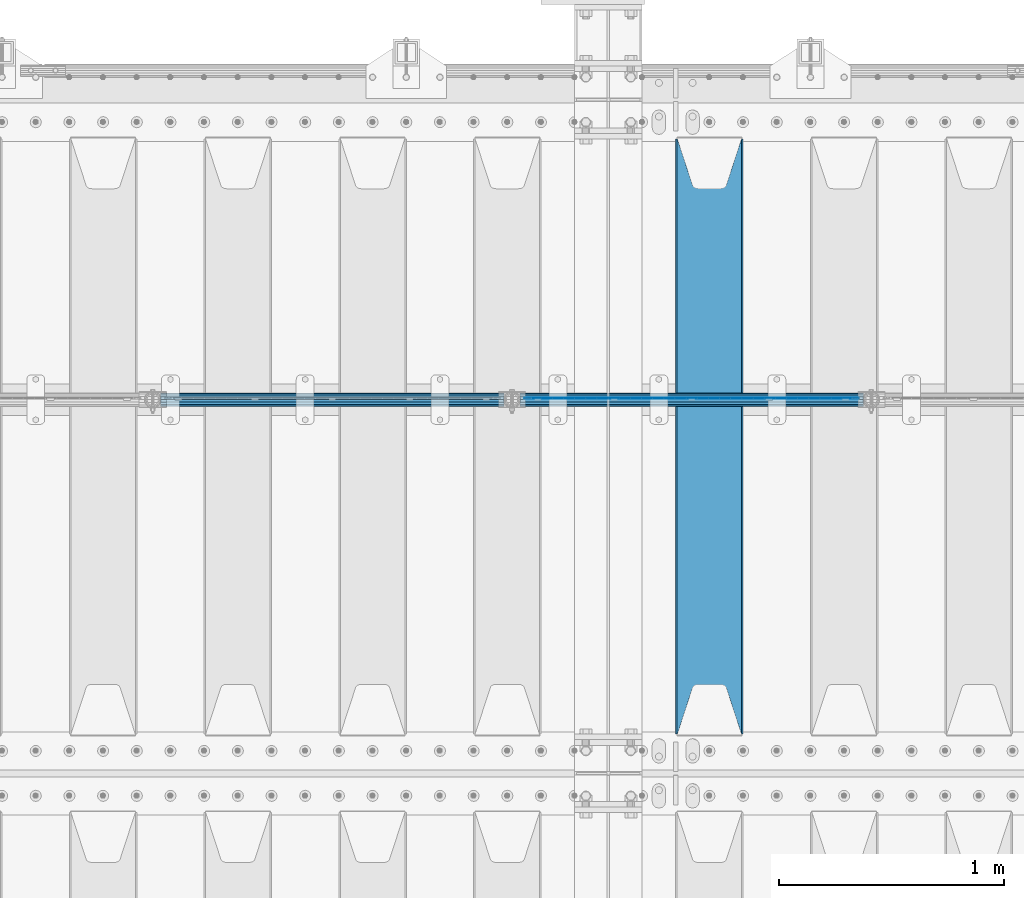
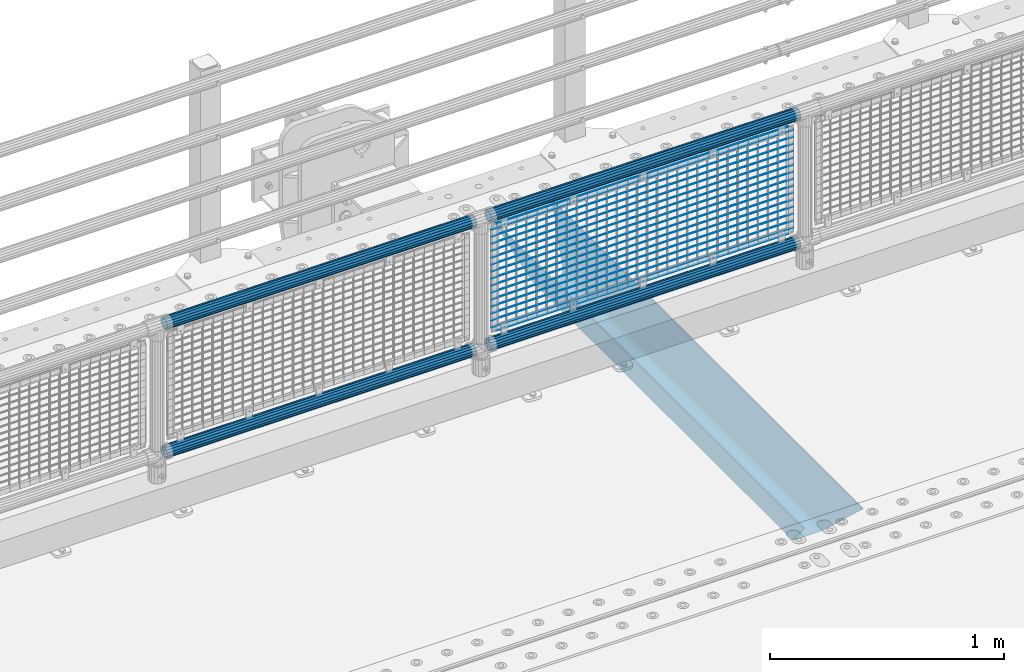
# One storey, part 126 of 257: 22 beams.
"""IFC2X3 building model written with IfcOpenShell, lengths in millimetres."""

import ifcopenshell
import ifcopenshell.guid

model = None  # the IFC model being written
_history = None  # IfcOwnerHistory: only IFC2X3 demands one
_inside = {}  # id of a spatial element -> (the spatial element, [elements in it])
_under = {}  # id of a project, library or spatial element -> (it, [spatial elements below it])
_declared = {}  # id of a project -> (the project, [libraries it declares])
_typed = {}  # id of a type object -> (the type object, [elements of that type])
_made_of = {}  # id of a material, layer set ... -> (it, [elements and type objects made of it])


def new_model(schema):
    """Start an empty IFC model of exactly this schema.

    Asked for "IFC4X3", IfcOpenShell would pick the latest addendum, in which some entities
    have other attributes; the version numbers below select the first issue.
    IFC2X3 requires an IfcOwnerHistory on every rooted entity: one is made here for all.
    """
    global model, _history
    if schema == "IFC4X3":
        model = ifcopenshell.file(schema_version=(4, 3, 0, 0))
    else:
        model = ifcopenshell.file(schema=schema)
    _inside.clear()
    _under.clear()
    _declared.clear()
    _typed.clear()
    _made_of.clear()
    _history = None
    if model.schema == "IFC2X3":
        org = make("IfcOrganization", Name="unknown")
        user = make(
            "IfcPersonAndOrganization",
            ThePerson=make("IfcPerson", FamilyName="unknown"),
            TheOrganization=org,
        )
        app = make(
            "IfcApplication",
            ApplicationDeveloper=org,
            Version="unknown",
            ApplicationFullName="unknown",
            ApplicationIdentifier="unknown",
        )
        _history = make(
            "IfcOwnerHistory",
            OwningUser=user,
            OwningApplication=app,
            ChangeAction="ADDED",
            CreationDate=0,
        )
    return model


def make(cls, **values):
    """One entity of the class cls with the attributes given. An attribute that is None is left unset."""
    return model.create_entity(
        cls, **{name: value for name, value in values.items() if value is not None}
    )


def rooted(cls, **values):
    """An entity with a GlobalId (a new one), such as an element, a storey or a relation."""
    return make(cls, GlobalId=ifcopenshell.guid.new(), OwnerHistory=_history, **values)


def si_unit(unit_type, name, prefix=None):
    """IfcSIUnit, for example si_unit("LENGTHUNIT", "METRE", prefix="MILLI")."""
    return make("IfcSIUnit", UnitType=unit_type, Prefix=prefix, Name=name)


def assignment(units):
    """IfcUnitAssignment: the units of a project."""
    return None if units is None else make("IfcUnitAssignment", Units=units)


def point(xyz):
    """IfcCartesianPoint."""
    return None if xyz is None else make("IfcCartesianPoint", Coordinates=xyz)


def direction(xyz):
    """IfcDirection."""
    return None if xyz is None else make("IfcDirection", DirectionRatios=xyz)


def frame(location, z_axis=None, x_axis=None):
    """IfcAxis2Placement3D, a coordinate frame: its origin and axes. An axis left out is left unset."""
    return make(
        "IfcAxis2Placement3D",
        Location=point(location),
        Axis=direction(z_axis),
        RefDirection=direction(x_axis),
    )


def origin_with_axes():
    """The frame at (0, 0, 0) with the z axis (0, 0, 1) and the x axis (1, 0, 0) written out."""
    return frame((0.0, 0.0, 0.0), z_axis=(0.0, 0.0, 1.0), x_axis=(1.0, 0.0, 0.0))


def place(relative_to, where):
    """IfcLocalPlacement: puts the frame where relative to a parent placement (None: the world)."""
    return make(
        "IfcLocalPlacement", PlacementRelTo=relative_to, RelativePlacement=where
    )


def context(
    kind, dimensions, precision=None, world=None, true_north=None, identifier=None
):
    """IfcGeometricRepresentationContext, for example the 3D "Model" context."""
    return make(
        "IfcGeometricRepresentationContext",
        ContextIdentifier=identifier,
        ContextType=kind,
        CoordinateSpaceDimension=dimensions,
        Precision=precision,
        WorldCoordinateSystem=world,
        TrueNorth=true_north,
    )


def subcontext(parent, identifier, kind, view, scale=None):
    """IfcGeometricRepresentationSubContext, for example "Body" below "Model"."""
    return make(
        "IfcGeometricRepresentationSubContext",
        ContextIdentifier=identifier,
        ContextType=kind,
        ParentContext=parent,
        TargetScale=scale,
        TargetView=view,
    )


def project(units=None, contexts=None):
    """IfcProject with its units and contexts."""
    return rooted(
        "IfcProject",
        Name="project",
        RepresentationContexts=contexts,
        UnitsInContext=assignment(units),
    )


def spatial(cls, under=None, at=None, **own):
    """A site, building, storey or space (cls), placed at a placement, below another one or the project."""
    s = rooted(cls, ObjectPlacement=at, **own)
    if under is not None:
        _under.setdefault(under.id(), (under, []))[1].append(s)
    return s


def faces_of(points, faces, orient=None, outer=None):
    """IfcFace entities. A face is a list of loops; a loop is a list of indices into points, from 0.

    orient and outer hold one flag for each loop. By default every Orientation is true, the
    first loop of a face is its IfcFaceOuterBound and the others are IfcFaceBound.
    """
    made = []
    for i, loops in enumerate(faces):
        bounds = []
        for j, loop in enumerate(loops):
            is_outer = j == 0 if outer is None else outer[i][j]
            bounds.append(
                make(
                    "IfcFaceOuterBound" if is_outer else "IfcFaceBound",
                    Bound=make("IfcPolyLoop", Polygon=[points[k] for k in loop]),
                    Orientation=True if orient is None else orient[i][j],
                )
            )
        made.append(make("IfcFace", Bounds=bounds))
    return made


def faceted_brep(points, faces, orient=None, outer=None, voids=None):
    """IfcFacetedBrep: a solid bounded by flat faces; with voids (closed shells), ...WithVoids."""
    shared = [point(p) for p in points]
    hull = make("IfcClosedShell", CfsFaces=faces_of(shared, faces, orient, outer))
    if voids is None:
        return make("IfcFacetedBrep", Outer=hull)
    return make(
        "IfcFacetedBrepWithVoids",
        Outer=hull,
        Voids=[
            make(cls, CfsFaces=faces_of(shared, fs, o, b)) for cls, fs, o, b in voids
        ],
    )


def shape(context_of_items, identifier, shape_type, items):
    """IfcShapeRepresentation: the items that make up one representation, for example the "Body"."""
    return make(
        "IfcShapeRepresentation",
        ContextOfItems=context_of_items,
        RepresentationIdentifier=identifier,
        RepresentationType=shape_type,
        Items=items,
    )


def material(Name=None, Category=None):
    """IfcMaterial."""
    return make("IfcMaterial", Name=Name, Category=Category)


def made_of(thing, what):
    """Note that an element or type object is made of a material, layer set ...; save() writes the relation."""
    if what is not None:
        _made_of.setdefault(what.id(), (what, []))[1].append(thing)
    return thing


def type_object(cls, material=None, **own):
    """A type object (cls), such as IfcWallType, which elements share."""
    return made_of(rooted(cls, **own), material)


def element(
    cls,
    number,
    at=None,
    inside=None,
    cuts=None,
    type_object=None,
    material=None,
    context=None,
    identifier="Body",
    shape_type=None,
    held_by="IfcProductDefinitionShape",
    body=None,
    shapes=None,
    **own,
):
    """One element of the class cls, such as IfcWall. Its Tag is "e" and its number.

    at: its placement. inside: the storey or other place that contains it. cuts: it is an
    opening in that element (IfcRelVoidsElement). A single representation is given by context,
    identifier, shape_type and body (its items); several are given by shapes. held_by: the class
    of the entity that holds the representations. save() writes the other relations.
    """
    e = rooted(cls, Tag="e%d" % number, ObjectPlacement=at, **own)
    if body is not None:
        shapes = [shape(context, identifier, shape_type, body)]
    if shapes is not None:
        e.Representation = make(held_by, Representations=shapes)
    if inside is not None:
        _inside.setdefault(inside.id(), (inside, []))[1].append(e)
    if cuts is not None:
        rooted(
            "IfcRelVoidsElement", RelatingBuildingElement=cuts, RelatedOpeningElement=e
        )
    if type_object is not None:
        _typed.setdefault(type_object.id(), (type_object, []))[1].append(e)
    return made_of(e, material)


def aggregate(whole, parts):
    """IfcRelAggregates: a whole, such as a stair, and the parts it consists of."""
    return rooted("IfcRelAggregates", RelatingObject=whole, RelatedObjects=parts)


def save(model, path):
    """Write the relations noted so far, then the file.

    IfcRelAggregates (storeys below a building ...), IfcRelContainedInSpatialStructure (elements
    in a storey), IfcRelDefinesByType, IfcRelAssociatesMaterial and IfcRelDeclares: one each for
    every whole, place, type object, material and project.
    """
    for whole, parts in _under.values():
        aggregate(whole, parts)
    for where, things in _inside.values():
        rooted(
            "IfcRelContainedInSpatialStructure",
            RelatedElements=things,
            RelatingStructure=where,
        )
    for kind, things in _typed.values():
        rooted("IfcRelDefinesByType", RelatedObjects=things, RelatingType=kind)
    for what, things in _made_of.values():
        rooted("IfcRelAssociatesMaterial", RelatedObjects=things, RelatingMaterial=what)
    for by, libraries in _declared.values():
        rooted("IfcRelDeclares", RelatingContext=by, RelatedDefinitions=libraries)
    model.write(path)


model = new_model("IFC2X3")

# Units and contexts
model_context = context("Model", 3, precision=1e-05, world=origin_with_axes())
body_context = subcontext(model_context, "Body", "Model", "MODEL_VIEW")
ifc_project = project(units=[si_unit("LENGTHUNIT", "METRE", prefix="MILLI"), si_unit("AREAUNIT", "SQUARE_METRE"), si_unit("VOLUMEUNIT", "CUBIC_METRE"), si_unit("MASSUNIT", "GRAM", prefix="KILO"), si_unit("TIMEUNIT", "SECOND"), si_unit("PLANEANGLEUNIT", "RADIAN"), si_unit("SOLIDANGLEUNIT", "STERADIAN"), si_unit("THERMODYNAMICTEMPERATUREUNIT", "DEGREE_CELSIUS"), si_unit("LUMINOUSINTENSITYUNIT", "LUMEN")], contexts=[model_context])

# Site, building, storey
site_placement = place(None, origin_with_axes())
site = spatial("IfcSite", under=ifc_project, at=site_placement, CompositionType="ELEMENT")
building_placement = place(site_placement, origin_with_axes())
building = spatial("IfcBuilding", under=site, at=building_placement, Name="Standard", CompositionType="ELEMENT")
storey_placement = place(building_placement, origin_with_axes())
storey = spatial("IfcBuildingStorey", under=building, at=storey_placement, Name="Undefined", CompositionType="ELEMENT", Elevation=0.0)

# Beams
ifc_material_1 = material(Name="STEEL/S355N")
beam_type_1 = type_object("IfcBeamType", PredefinedType="NOTDEFINED")
beam_1_placement = place(storey_placement, frame((55150.0, 9175.0, -115.0), z_axis=(0.0, 0.0, 1.0), x_axis=(0.0, 1.0, 0.0)))
element("IfcBeam", 1, at=beam_1_placement, inside=storey, type_object=beam_type_1, material=ifc_material_1, context=body_context, shape_type="Brep", body=[
    faceted_brep([(0.0, 150.0, 115.0), (0.0, 143.690000000002, 115.0), (2650.00000000297, 143.690000000002, 115.0), (2650.00000000297, 150.0, 115.0), (2650.00000000297, 142.059565218406, 110.0000000031), (2650.00000000297, 148.369565218403, 110.0000000031), (2441.90079219208, -80.1103600731149, -98.0992078077845), (2437.7588105432, -77.5672621345584, -102.241189456673), (2434.06523489746, -74.4080125315522, -105.934765102404), (2430.91086095089, -70.7102721255724, -109.089139048974), (2428.37322971128, -66.5649389910031, -111.626770288588), (2426.51472138055, -62.0739139532889, -113.485278619323), (2425.38102192091, -57.3475956567636, -114.618978078955), (2424.99999999987, -52.5021667386536, -115.0), (2424.99999999987, 52.5021667386536, -115.0), (2425.38102192091, 57.3475956567636, -114.618978078955), (2426.51472138055, 62.0739139532889, -113.485278619323), (2428.37322971128, 66.5649389910031, -111.626770288588), (2430.91086095089, 70.7102721255724, -109.089139048974), (2434.06523489746, 74.4080125315522, -105.934765102404), (2437.7588105432, 77.5672621345584, -102.241189456673), (2441.90079219208, 80.1103600731149, -98.0992078077846), (2446.38936140511, 81.9747917625791, -93.6106385947584), (2448.24948500409, 76.2713538057287, -91.7505149957729), (2444.62967112262, 74.76777986261, -95.3703288772456), (2441.28936334126, 72.7168944282894, -98.710636658607), (2438.31067330438, 70.1691124903809, -101.689326695487), (2435.76682334747, 67.1870637758839, -104.233176652398), (2433.72034654133, 63.8440531834931, -106.279653458539), (2432.22154950041, 60.2222587982324, -107.778450499454), (2431.30727574265, 56.4107117849126, -108.692724257221), (2430.99999999987, 52.5031078186876, -109.0), (2430.99999999987, -52.5031078186876, -109.0), (2431.30727574265, -56.4107117849126, -108.692724257221), (2432.22154950041, -60.2222587982324, -107.778450499454), (2433.72034654133, -63.8440531834931, -106.279653458539), (2435.76682334747, -67.1870637758839, -104.233176652398), (2438.31067330438, -70.1691124903809, -101.689326695487), (2441.28936334126, -72.7168944282894, -98.7106366586071), (2444.62967112262, -74.76777986261, -95.3703288772457), (2448.24948500409, -76.2713538057287, -91.7505149957729), (2650.00000000297, -142.059565218406, 110.0000000031), (2650.00000000297, -148.369565218403, 110.0000000031), (2446.38936140511, -81.9747917625791, -93.6106385947584), (2650.00000000297, -143.690000000002, 115.0), (2650.00000000297, -150.0, 115.0), (0.0, -143.690000000002, 115.0), (0.0, -150.0, 115.0), (0.0, -148.369565218258, 110.000000002662), (203.61063859742, -81.9747917625791, -93.6106385947584), (208.099207810447, -80.1103600731149, -98.0992078077845), (212.241189459335, -77.5672621345584, -102.241189456673), (215.934765105066, -74.4080125315522, -105.934765102404), (219.089139051636, -70.7102721255724, -109.089139048974), (221.626770291251, -66.5649389910031, -111.626770288588), (223.485278621985, -62.0739139532889, -113.485278619323), (224.618978081617, -57.3475956567636, -114.618978078955), (225.000000002662, -52.5021667386536, -115.0), (225.000000002662, 52.5021667386536, -115.0), (224.618978081617, 57.3475956567636, -114.618978078955), (223.485278621985, 62.0739139532889, -113.485278619323), (221.626770291251, 66.5649389910031, -111.626770288588), (219.089139051636, 70.7102721255724, -109.089139048974), (215.934765105066, 74.4080125315522, -105.934765102404), (212.241189459335, 77.5672621345584, -102.241189456673), (208.099207810447, 80.1103600731149, -98.0992078077846), (203.61063859742, 81.9747917625791, -93.6106385947584), (0.0, 148.369565218258, 110.000000002662), (0.0, 142.05956521826, 110.000000002662), (201.750514998435, 76.2713538057287, -91.7505149957729), (205.370328879908, 74.76777986261, -95.3703288772456), (208.710636661269, 72.7168944282894, -98.710636658607), (211.689326698149, 70.1691124903809, -101.689326695487), (214.233176655061, 67.1870637758839, -104.233176652398), (216.279653461201, 63.8440531834931, -106.279653458539), (217.778450502116, 60.2222587982324, -107.778450499454), (218.692724259884, 56.4107117849126, -108.692724257221), (219.000000002662, 52.5031078186876, -109.0), (219.000000002662, -52.5031078186876, -109.0), (218.692724259884, -56.4107117849126, -108.692724257221), (217.778450502116, -60.2222587982324, -107.778450499454), (216.279653461201, -63.8440531834931, -106.279653458539), (214.233176655061, -67.1870637758839, -104.233176652398), (211.689326698149, -70.1691124903809, -101.689326695487), (208.710636661269, -72.7168944282894, -98.7106366586071), (205.370328879908, -74.76777986261, -95.3703288772457), (201.750514998435, -76.2713538057287, -91.7505149957729), (0.0, -142.05956521826, 110.000000002662)], [[[0, 1, 2, 3]], [[3, 2, 4, 5]], [[6, 7, 8, 9, 10, 11, 12, 13, 14, 15, 16, 17, 18, 19, 20, 21, 22, 5, 4, 23, 24, 25, 26, 27, 28, 29, 30, 31, 32, 33, 34, 35, 36, 37, 38, 39, 40, 41, 42, 43]], [[44, 45, 42, 41]], [[46, 47, 45, 44]], [[43, 42, 45, 47, 48, 49]], [[6, 43, 49, 50]], [[7, 6, 50, 51]], [[8, 7, 51, 52]], [[9, 8, 52, 53]], [[10, 9, 53, 54]], [[11, 10, 54, 55]], [[12, 11, 55, 56]], [[13, 12, 56, 57]], [[14, 13, 57, 58]], [[15, 14, 58, 59]], [[16, 15, 59, 60]], [[17, 16, 60, 61]], [[18, 17, 61, 62]], [[19, 18, 62, 63]], [[20, 19, 63, 64]], [[21, 20, 64, 65]], [[22, 21, 65, 66]], [[0, 3, 5, 22, 66, 67]], [[1, 0, 67, 68]], [[23, 4, 2, 1, 68, 69]], [[24, 23, 69, 70]], [[25, 24, 70, 71]], [[26, 25, 71, 72]], [[27, 26, 72, 73]], [[28, 27, 73, 74]], [[29, 28, 74, 75]], [[30, 29, 75, 76]], [[31, 30, 76, 77]], [[32, 31, 77, 78]], [[33, 32, 78, 79]], [[34, 33, 79, 80]], [[35, 34, 80, 81]], [[36, 35, 81, 82]], [[37, 36, 82, 83]], [[38, 37, 83, 84]], [[39, 38, 84, 85]], [[40, 39, 85, 86]], [[46, 44, 41, 40, 86, 87]], [[47, 46, 87, 48]], [[86, 85, 84, 83, 82, 81, 80, 79, 78, 77, 76, 75, 74, 73, 72, 71, 70, 69, 68, 67, 66, 65, 64, 63, 62, 61, 60, 59, 58, 57, 56, 55, 54, 53, 52, 51, 50, 49, 48, 87]]]),
])
ifc_material_2 = material(Name="Misc_Undefined")
beam_type_2 = type_object("IfcBeamType", Name="D3", PredefinedType="NOTDEFINED")
for number, where, z_axis, x_axis in (
    (2, (54326.0, 10670.5, 851.597000000005), (0.0, 0.0, 1.0), (1.0, 0.0, 0.0)),
    (3, (54326.0, 10670.5, 669.452000000005), (0.0, 0.0, 1.0), (1.0, 0.0, 0.0)),
    (4, (54326.0, 10670.5, 523.736000000005), (0.0, 0.0, 1.0), (1.0, 0.0, 0.0)),
    (5, (54326.0, 10670.5, 487.307000000005), (0.0, 0.0, 1.0), (1.0, 0.0, 0.0)),
    (6, (54326.0, 10670.5, 705.881000000005), (0.0, 0.0, 1.0), (1.0, 0.0, 0.0)),
    (7, (54326.0, 10670.5, 596.594000000005), (0.0, 0.0, 1.0), (1.0, 0.0, 0.0)),
    (8, (54326.0, 10670.5, 450.878000000005), (0.0, 0.0, 1.0), (1.0, 0.0, 0.0)),
    (9, (54326.0, 10670.5, 815.168000000005), (0.0, 0.0, 1.0), (1.0, 0.0, 0.0)),
    (10, (54326.0, 10670.5, 888.026000000005), (0.0, 0.0, 1.0), (1.0, 0.0, 0.0)),
    (11, (54326.0, 10670.5, 778.739000000005), (0.0, 0.0, 1.0), (1.0, 0.0, 0.0)),
    (12, (54326.0, 10670.5, 742.310000000005), (0.0, 0.0, 1.0), (1.0, 0.0, 0.0)),
    (13, (54326.0, 10670.5, 633.023000000005), (0.0, 0.0, 1.0), (1.0, 0.0, 0.0)),
    (14, (54326.0, 10670.5, 560.165000000005), (0.0, 0.0, 1.0), (1.0, 0.0, 0.0)),
    (15, (54326.0, 10670.5, 414.449000000005), (0.0, 0.0, 1.0), (1.0, 0.0, 0.0)),
):
    element("IfcBeam", number, at=place(storey_placement, frame(where, z_axis=z_axis, x_axis=x_axis)), inside=storey, type_object=beam_type_2, material=ifc_material_2, ObjectType="D3", context=body_context, shape_type="Brep", body=[
        faceted_brep([(0.0, -1.5, -5.6843418860808e-14), (0.0, -0.750000000001819, -1.29903810567669), (1490.0, -0.75, -1.29903810567669), (1490.0, -1.5, 0.0), (7.27595761418343e-12, 0.749999999998181, -1.29903810567669), (1490.0, 0.75, -1.29903810567669), (0.0, 1.5, -5.6843418860808e-14), (1490.0, 1.5, 0.0), (7.27595761418343e-12, 0.749999999998181, 1.29903810567669), (1490.0, 0.75, 1.29903810567669), (0.0, -0.750000000001819, 1.29903810567669), (1490.0, -0.75, 1.29903810567669)], [[[0, 1, 2, 3]], [[1, 4, 5, 2]], [[4, 6, 7, 5]], [[6, 8, 9, 7]], [[8, 10, 11, 9]], [[10, 0, 3, 11]], [[5, 7, 9, 11, 3, 2]], [[10, 8, 6, 4, 1, 0]]]),
    ])
beam_2_placement = place(storey_placement, frame((54351.0, 10670.5, 353.020000000005), z_axis=(0.0, 0.0, 1.0), x_axis=(1.0, 0.0, 0.0)))
element("IfcBeam", 16, at=beam_2_placement, inside=storey, type_object=beam_type_2, material=ifc_material_2, ObjectType="D3", context=body_context, shape_type="Brep", body=[
    faceted_brep([(0.0, -1.5, -5.6843418860808e-14), (0.0, -0.750000000001819, -1.29903810567669), (1440.0, -0.75, -1.29903810567669), (1440.0, -1.5, 0.0), (7.27595761418343e-12, 0.749999999998181, -1.29903810567669), (1440.0, 0.75, -1.29903810567663), (0.0, 1.5, -5.6843418860808e-14), (1440.0, 1.5, 0.0), (7.27595761418343e-12, 0.749999999998181, 1.29903810567669), (1440.0, 0.75, 1.29903810567669), (0.0, -0.750000000001819, 1.29903810567669), (1440.0, -0.75, 1.29903810567669)], [[[0, 1, 2, 3]], [[1, 4, 5, 2]], [[4, 6, 7, 5]], [[6, 8, 9, 7]], [[8, 10, 11, 9]], [[10, 0, 3, 11]], [[5, 7, 9, 11, 3, 2]], [[10, 8, 6, 4, 1, 0]]]),
])
beam_3_placement = place(storey_placement, frame((54326.0, 10670.5, 378.020000000005), z_axis=(0.0, 0.0, 1.0), x_axis=(1.0, 0.0, 0.0)))
element("IfcBeam", 17, at=beam_3_placement, inside=storey, type_object=beam_type_2, material=ifc_material_2, ObjectType="D3", context=body_context, shape_type="Brep", body=[
    faceted_brep([(0.0, -1.5, -5.6843418860808e-14), (0.0, -0.750000000001819, -1.29903810567669), (1490.0, -0.75, -1.29903810567669), (1490.0, -1.5, 0.0), (7.27595761418343e-12, 0.749999999998181, -1.29903810567669), (1490.0, 0.75, -1.29903810567669), (0.0, 1.5, -5.6843418860808e-14), (1490.0, 1.5, 0.0), (7.27595761418343e-12, 0.749999999998181, 1.29903810567669), (1490.0, 0.75, 1.29903810567669), (0.0, -0.750000000001819, 1.29903810567669), (1490.0, -0.75, 1.29903810567669)], [[[0, 1, 2, 3]], [[1, 4, 5, 2]], [[4, 6, 7, 5]], [[6, 8, 9, 7]], [[8, 10, 11, 9]], [[10, 0, 3, 11]], [[5, 7, 9, 11, 3, 2]], [[10, 8, 6, 4, 1, 0]]]),
])
beam_4_placement = place(storey_placement, frame((54351.0, 10670.5, 913.020000000005), z_axis=(0.0, 0.0, 1.0), x_axis=(1.0, 0.0, 0.0)))
element("IfcBeam", 18, at=beam_4_placement, inside=storey, type_object=beam_type_2, material=ifc_material_2, ObjectType="D3", context=body_context, shape_type="Brep", body=[
    faceted_brep([(0.0, -1.5, -5.6843418860808e-14), (0.0, -0.750000000001819, -1.29903810567669), (1440.0, -0.75, -1.29903810567669), (1440.0, -1.5, 0.0), (7.27595761418343e-12, 0.749999999998181, -1.29903810567669), (1440.0, 0.75, -1.29903810567663), (0.0, 1.5, -5.6843418860808e-14), (1440.0, 1.5, 0.0), (7.27595761418343e-12, 0.749999999998181, 1.29903810567669), (1440.0, 0.75, 1.29903810567669), (0.0, -0.750000000001819, 1.29903810567669), (1440.0, -0.75, 1.29903810567669)], [[[0, 1, 2, 3]], [[1, 4, 5, 2]], [[4, 6, 7, 5]], [[6, 8, 9, 7]], [[8, 10, 11, 9]], [[10, 0, 3, 11]], [[5, 7, 9, 11, 3, 2]], [[10, 8, 6, 4, 1, 0]]]),
])
ifc_material_3 = material()
beam_type_3 = type_object("IfcBeamType", PredefinedType="NOTDEFINED")
beam_5_placement = place(storey_placement, frame((54305.85, 10664.5, 298.170000000006), z_axis=(0.0, 0.0, 1.0), x_axis=(1.0, 0.0, 0.0)))
element("IfcBeam", 19, at=beam_5_placement, inside=storey, type_object=beam_type_3, material=ifc_material_3, context=body_context, shape_type="Brep", body=[
    faceted_brep([(0.0, -25.3500000000004, 0.0), (0.0, -23.4203461491616, 9.70102501045767), (1530.0, -23.4203461491616, 9.70102501045506), (1530.0, -25.3500000000004, 0.0), (0.0, -17.9251569030785, 17.9251569030821), (1530.0, -17.9251569030785, 17.925156903079), (0.0, -9.70102501045585, 23.4203461491634), (1530.0, -9.70102501045585, 23.4203461491611), (0.0, 0.0, 25.3499999999985), (1530.0, 0.0, 25.35), (0.0, 9.70102501045585, 23.4203461491634), (1530.0, 9.70102501045585, 23.4203461491611), (0.0, 17.9251569030785, 17.9251569030821), (1530.0, 17.9251569030785, 17.925156903079), (0.0, 23.4203461491616, 9.70102501045767), (1530.0, 23.4203461491616, 9.701025010455), (0.0, 25.3500000000004, 0.0), (1530.0, 25.3500000000004, 0.0), (0.0, 23.4203461491616, -9.70102501045767), (1530.0, 23.4203461491616, -9.70102501045506), (0.0, 17.9251569030785, -17.9251569030821), (1530.0, 17.9251569030785, -17.925156903079), (0.0, 9.70102501045585, -23.4203461491634), (1530.0, 9.70102501045585, -23.4203461491611), (0.0, 0.0, -25.3499999999985), (1530.0, 0.0, -25.35), (0.0, -9.70102501045585, -23.4203461491634), (1530.0, -9.70102501045585, -23.4203461491611), (0.0, -17.9251569030785, -17.9251569030821), (1530.0, -17.9251569030785, -17.925156903079), (0.0, -23.4203461491616, -9.70102501045767), (1530.0, -23.4203461491616, -9.701025010455), (0.0, -30.1499999999996, 0.0), (0.0, -27.8549679052157, -11.5379054858058), (1530.0, -27.8549679052157, -11.5379054858075), (1530.0, -30.1499999999996, 0.0), (0.0, -21.3192694527752, -21.3192694527752), (1530.0, -21.3192694527752, -21.3192694527744), (0.0, -11.5379054858076, -27.8549679052157), (1530.0, -11.5379054858076, -27.8549679052153), (0.0, 0.0, -30.1500000000015), (1530.0, 0.0, -30.15), (0.0, 11.5379054858076, -27.8549679052157), (1530.0, 11.5379054858076, -27.8549679052153), (0.0, 21.3192694527752, -21.3192694527752), (1530.0, 21.3192694527752, -21.3192694527744), (0.0, 27.8549679052157, -11.5379054858058), (1530.0, 27.8549679052157, -11.5379054858075), (0.0, 30.1499999999996, 0.0), (1530.0, 30.1499999999996, 0.0), (0.0, 27.8549679052157, 11.5379054858058), (1530.0, 27.8549679052157, 11.5379054858075), (0.0, 21.3192694527752, 21.3192694527752), (1530.0, 21.3192694527752, 21.3192694527744), (0.0, 11.5379054858076, 27.8549679052157), (1530.0, 11.5379054858076, 27.8549679052153), (0.0, 0.0, 30.1500000000015), (1530.0, 0.0, 30.15), (0.0, -11.5379054858076, 27.8549679052157), (1530.0, -11.5379054858076, 27.8549679052153), (0.0, -21.3192694527752, 21.3192694527752), (1530.0, -21.3192694527752, 21.3192694527744), (0.0, -27.8549679052157, 11.5379054858058), (1530.0, -27.8549679052157, 11.5379054858075)], [[[0, 1, 2, 3]], [[1, 4, 5, 2]], [[4, 6, 7, 5]], [[6, 8, 9, 7]], [[8, 10, 11, 9]], [[10, 12, 13, 11]], [[12, 14, 15, 13]], [[14, 16, 17, 15]], [[16, 18, 19, 17]], [[18, 20, 21, 19]], [[20, 22, 23, 21]], [[22, 24, 25, 23]], [[24, 26, 27, 25]], [[26, 28, 29, 27]], [[28, 30, 31, 29]], [[30, 0, 3, 31]], [[32, 33, 34, 35]], [[33, 36, 37, 34]], [[36, 38, 39, 37]], [[38, 40, 41, 39]], [[40, 42, 43, 41]], [[42, 44, 45, 43]], [[44, 46, 47, 45]], [[46, 48, 49, 47]], [[48, 50, 51, 49]], [[50, 52, 53, 51]], [[52, 54, 55, 53]], [[54, 56, 57, 55]], [[56, 58, 59, 57]], [[58, 60, 61, 59]], [[60, 62, 63, 61]], [[62, 32, 35, 63]], [[37, 39, 41, 43, 45, 47, 49, 51, 53, 55, 57, 59, 61, 63, 35, 34], [5, 7, 9, 11, 13, 15, 17, 19, 21, 23, 25, 27, 29, 31, 3, 2]], [[62, 60, 58, 56, 54, 52, 50, 48, 46, 44, 42, 40, 38, 36, 33, 32], [30, 28, 26, 24, 22, 20, 18, 16, 14, 12, 10, 8, 6, 4, 1, 0]]]),
])
beam_6_placement = place(storey_placement, frame((54305.85, 10664.5, 969.850000000005), z_axis=(0.0, 0.0, 1.0), x_axis=(1.0, 0.0, 0.0)))
element("IfcBeam", 20, at=beam_6_placement, inside=storey, type_object=beam_type_3, material=ifc_material_3, context=body_context, shape_type="Brep", body=[
    faceted_brep([(0.0, -25.3500000000004, 0.0), (0.0, -23.4203461491616, 9.70102501045767), (1530.0, -23.4203461491616, 9.70102501045506), (1530.0, -25.3500000000004, 0.0), (0.0, -17.9251569030785, 17.9251569030821), (1530.0, -17.9251569030785, 17.925156903079), (0.0, -9.70102501045585, 23.4203461491634), (1530.0, -9.70102501045585, 23.4203461491611), (0.0, 0.0, 25.3499999999985), (1530.0, 0.0, 25.35), (0.0, 9.70102501045585, 23.4203461491634), (1530.0, 9.70102501045585, 23.4203461491611), (0.0, 17.9251569030785, 17.9251569030821), (1530.0, 17.9251569030785, 17.925156903079), (0.0, 23.4203461491616, 9.70102501045767), (1530.0, 23.4203461491616, 9.701025010455), (0.0, 25.3500000000004, 0.0), (1530.0, 25.3500000000004, 0.0), (0.0, 23.4203461491616, -9.70102501045767), (1530.0, 23.4203461491616, -9.70102501045506), (0.0, 17.9251569030785, -17.9251569030821), (1530.0, 17.9251569030785, -17.925156903079), (0.0, 9.70102501045585, -23.4203461491634), (1530.0, 9.70102501045585, -23.4203461491611), (0.0, 0.0, -25.3499999999985), (1530.0, 0.0, -25.35), (0.0, -9.70102501045585, -23.4203461491634), (1530.0, -9.70102501045585, -23.4203461491611), (0.0, -17.9251569030785, -17.9251569030821), (1530.0, -17.9251569030785, -17.925156903079), (0.0, -23.4203461491616, -9.70102501045767), (1530.0, -23.4203461491616, -9.701025010455), (0.0, -30.1499999999996, 0.0), (0.0, -27.8549679052157, -11.5379054858058), (1530.0, -27.8549679052157, -11.5379054858075), (1530.0, -30.1499999999996, 0.0), (0.0, -21.3192694527752, -21.3192694527752), (1530.0, -21.3192694527752, -21.3192694527744), (0.0, -11.5379054858076, -27.8549679052157), (1530.0, -11.5379054858076, -27.8549679052153), (0.0, 0.0, -30.1500000000015), (1530.0, 0.0, -30.15), (0.0, 11.5379054858076, -27.8549679052157), (1530.0, 11.5379054858076, -27.8549679052153), (0.0, 21.3192694527752, -21.3192694527752), (1530.0, 21.3192694527752, -21.3192694527744), (0.0, 27.8549679052157, -11.5379054858058), (1530.0, 27.8549679052157, -11.5379054858075), (0.0, 30.1499999999996, 0.0), (1530.0, 30.1499999999996, 0.0), (0.0, 27.8549679052157, 11.5379054858058), (1530.0, 27.8549679052157, 11.5379054858075), (0.0, 21.3192694527752, 21.3192694527752), (1530.0, 21.3192694527752, 21.3192694527744), (0.0, 11.5379054858076, 27.8549679052157), (1530.0, 11.5379054858076, 27.8549679052153), (0.0, 0.0, 30.1500000000015), (1530.0, 0.0, 30.15), (0.0, -11.5379054858076, 27.8549679052157), (1530.0, -11.5379054858076, 27.8549679052153), (0.0, -21.3192694527752, 21.3192694527752), (1530.0, -21.3192694527752, 21.3192694527744), (0.0, -27.8549679052157, 11.5379054858058), (1530.0, -27.8549679052157, 11.5379054858075)], [[[0, 1, 2, 3]], [[1, 4, 5, 2]], [[4, 6, 7, 5]], [[6, 8, 9, 7]], [[8, 10, 11, 9]], [[10, 12, 13, 11]], [[12, 14, 15, 13]], [[14, 16, 17, 15]], [[16, 18, 19, 17]], [[18, 20, 21, 19]], [[20, 22, 23, 21]], [[22, 24, 25, 23]], [[24, 26, 27, 25]], [[26, 28, 29, 27]], [[28, 30, 31, 29]], [[30, 0, 3, 31]], [[32, 33, 34, 35]], [[33, 36, 37, 34]], [[36, 38, 39, 37]], [[38, 40, 41, 39]], [[40, 42, 43, 41]], [[42, 44, 45, 43]], [[44, 46, 47, 45]], [[46, 48, 49, 47]], [[48, 50, 51, 49]], [[50, 52, 53, 51]], [[52, 54, 55, 53]], [[54, 56, 57, 55]], [[56, 58, 59, 57]], [[58, 60, 61, 59]], [[60, 62, 63, 61]], [[62, 32, 35, 63]], [[37, 39, 41, 43, 45, 47, 49, 51, 53, 55, 57, 59, 61, 63, 35, 34], [5, 7, 9, 11, 13, 15, 17, 19, 21, 23, 25, 27, 29, 31, 3, 2]], [[62, 60, 58, 56, 54, 52, 50, 48, 46, 44, 42, 40, 38, 36, 33, 32], [30, 28, 26, 24, 22, 20, 18, 16, 14, 12, 10, 8, 6, 4, 1, 0]]]),
])
beam_7_placement = place(storey_placement, frame((52705.85, 10664.5, 298.170000000005), z_axis=(0.0, 0.0, 1.0), x_axis=(1.0, 0.0, 0.0)))
element("IfcBeam", 21, at=beam_7_placement, inside=storey, type_object=beam_type_3, material=ifc_material_3, context=body_context, shape_type="Brep", body=[
    faceted_brep([(0.0, -25.3500000000004, 0.0), (0.0, -23.4203461491616, 9.70102501045767), (1530.0, -23.4203461491616, 9.70102501045506), (1530.0, -25.3500000000004, 0.0), (0.0, -17.9251569030785, 17.9251569030821), (1530.0, -17.9251569030785, 17.925156903079), (0.0, -9.70102501045585, 23.4203461491634), (1530.0, -9.70102501045585, 23.4203461491611), (0.0, 0.0, 25.3499999999985), (1530.0, 0.0, 25.35), (0.0, 9.70102501045585, 23.4203461491634), (1530.0, 9.70102501045585, 23.4203461491611), (0.0, 17.9251569030785, 17.9251569030821), (1530.0, 17.9251569030785, 17.925156903079), (0.0, 23.4203461491616, 9.70102501045767), (1530.0, 23.4203461491616, 9.701025010455), (0.0, 25.3500000000004, 0.0), (1530.0, 25.3500000000004, 0.0), (0.0, 23.4203461491616, -9.70102501045767), (1530.0, 23.4203461491616, -9.70102501045506), (0.0, 17.9251569030785, -17.9251569030821), (1530.0, 17.9251569030785, -17.925156903079), (0.0, 9.70102501045585, -23.4203461491634), (1530.0, 9.70102501045585, -23.4203461491611), (0.0, 0.0, -25.3499999999985), (1530.0, 0.0, -25.35), (0.0, -9.70102501045585, -23.4203461491634), (1530.0, -9.70102501045585, -23.4203461491611), (0.0, -17.9251569030785, -17.9251569030821), (1530.0, -17.9251569030785, -17.925156903079), (0.0, -23.4203461491616, -9.70102501045767), (1530.0, -23.4203461491616, -9.701025010455), (0.0, -30.1499999999996, 0.0), (0.0, -27.8549679052157, -11.5379054858058), (1530.0, -27.8549679052157, -11.5379054858075), (1530.0, -30.1499999999996, 0.0), (0.0, -21.3192694527752, -21.3192694527752), (1530.0, -21.3192694527752, -21.3192694527744), (0.0, -11.5379054858076, -27.8549679052157), (1530.0, -11.5379054858076, -27.8549679052153), (0.0, 0.0, -30.1500000000015), (1530.0, 0.0, -30.15), (0.0, 11.5379054858076, -27.8549679052157), (1530.0, 11.5379054858076, -27.8549679052153), (0.0, 21.3192694527752, -21.3192694527752), (1530.0, 21.3192694527752, -21.3192694527744), (0.0, 27.8549679052157, -11.5379054858058), (1530.0, 27.8549679052157, -11.5379054858075), (0.0, 30.1499999999996, 0.0), (1530.0, 30.1499999999996, 0.0), (0.0, 27.8549679052157, 11.5379054858058), (1530.0, 27.8549679052157, 11.5379054858075), (0.0, 21.3192694527752, 21.3192694527752), (1530.0, 21.3192694527752, 21.3192694527744), (0.0, 11.5379054858076, 27.8549679052157), (1530.0, 11.5379054858076, 27.8549679052153), (0.0, 0.0, 30.1500000000015), (1530.0, 0.0, 30.15), (0.0, -11.5379054858076, 27.8549679052157), (1530.0, -11.5379054858076, 27.8549679052153), (0.0, -21.3192694527752, 21.3192694527752), (1530.0, -21.3192694527752, 21.3192694527744), (0.0, -27.8549679052157, 11.5379054858058), (1530.0, -27.8549679052157, 11.5379054858075)], [[[0, 1, 2, 3]], [[1, 4, 5, 2]], [[4, 6, 7, 5]], [[6, 8, 9, 7]], [[8, 10, 11, 9]], [[10, 12, 13, 11]], [[12, 14, 15, 13]], [[14, 16, 17, 15]], [[16, 18, 19, 17]], [[18, 20, 21, 19]], [[20, 22, 23, 21]], [[22, 24, 25, 23]], [[24, 26, 27, 25]], [[26, 28, 29, 27]], [[28, 30, 31, 29]], [[30, 0, 3, 31]], [[32, 33, 34, 35]], [[33, 36, 37, 34]], [[36, 38, 39, 37]], [[38, 40, 41, 39]], [[40, 42, 43, 41]], [[42, 44, 45, 43]], [[44, 46, 47, 45]], [[46, 48, 49, 47]], [[48, 50, 51, 49]], [[50, 52, 53, 51]], [[52, 54, 55, 53]], [[54, 56, 57, 55]], [[56, 58, 59, 57]], [[58, 60, 61, 59]], [[60, 62, 63, 61]], [[62, 32, 35, 63]], [[37, 39, 41, 43, 45, 47, 49, 51, 53, 55, 57, 59, 61, 63, 35, 34], [5, 7, 9, 11, 13, 15, 17, 19, 21, 23, 25, 27, 29, 31, 3, 2]], [[62, 60, 58, 56, 54, 52, 50, 48, 46, 44, 42, 40, 38, 36, 33, 32], [30, 28, 26, 24, 22, 20, 18, 16, 14, 12, 10, 8, 6, 4, 1, 0]]]),
])
beam_8_placement = place(storey_placement, frame((52705.85, 10664.5, 969.850000000004), z_axis=(0.0, 0.0, 1.0), x_axis=(1.0, 0.0, 0.0)))
element("IfcBeam", 22, at=beam_8_placement, inside=storey, type_object=beam_type_3, material=ifc_material_3, context=body_context, shape_type="Brep", body=[
    faceted_brep([(0.0, -25.3500000000004, 0.0), (0.0, -23.4203461491616, 9.70102501045767), (1530.0, -23.4203461491616, 9.70102501045506), (1530.0, -25.3500000000004, 0.0), (0.0, -17.9251569030785, 17.9251569030821), (1530.0, -17.9251569030785, 17.925156903079), (0.0, -9.70102501045585, 23.4203461491634), (1530.0, -9.70102501045585, 23.4203461491611), (0.0, 0.0, 25.3499999999985), (1530.0, 0.0, 25.35), (0.0, 9.70102501045585, 23.4203461491634), (1530.0, 9.70102501045585, 23.4203461491611), (0.0, 17.9251569030785, 17.9251569030821), (1530.0, 17.9251569030785, 17.925156903079), (0.0, 23.4203461491616, 9.70102501045767), (1530.0, 23.4203461491616, 9.701025010455), (0.0, 25.3500000000004, 0.0), (1530.0, 25.3500000000004, 0.0), (0.0, 23.4203461491616, -9.70102501045767), (1530.0, 23.4203461491616, -9.70102501045506), (0.0, 17.9251569030785, -17.9251569030821), (1530.0, 17.9251569030785, -17.925156903079), (0.0, 9.70102501045585, -23.4203461491634), (1530.0, 9.70102501045585, -23.4203461491611), (0.0, 0.0, -25.3499999999985), (1530.0, 0.0, -25.35), (0.0, -9.70102501045585, -23.4203461491634), (1530.0, -9.70102501045585, -23.4203461491611), (0.0, -17.9251569030785, -17.9251569030821), (1530.0, -17.9251569030785, -17.925156903079), (0.0, -23.4203461491616, -9.70102501045767), (1530.0, -23.4203461491616, -9.701025010455), (0.0, -30.1499999999996, 0.0), (0.0, -27.8549679052157, -11.5379054858058), (1530.0, -27.8549679052157, -11.5379054858075), (1530.0, -30.1499999999996, 0.0), (0.0, -21.3192694527752, -21.3192694527752), (1530.0, -21.3192694527752, -21.3192694527744), (0.0, -11.5379054858076, -27.8549679052157), (1530.0, -11.5379054858076, -27.8549679052153), (0.0, 0.0, -30.1500000000015), (1530.0, 0.0, -30.15), (0.0, 11.5379054858076, -27.8549679052157), (1530.0, 11.5379054858076, -27.8549679052153), (0.0, 21.3192694527752, -21.3192694527752), (1530.0, 21.3192694527752, -21.3192694527744), (0.0, 27.8549679052157, -11.5379054858058), (1530.0, 27.8549679052157, -11.5379054858075), (0.0, 30.1499999999996, 0.0), (1530.0, 30.1499999999996, 0.0), (0.0, 27.8549679052157, 11.5379054858058), (1530.0, 27.8549679052157, 11.5379054858075), (0.0, 21.3192694527752, 21.3192694527752), (1530.0, 21.3192694527752, 21.3192694527744), (0.0, 11.5379054858076, 27.8549679052157), (1530.0, 11.5379054858076, 27.8549679052153), (0.0, 0.0, 30.1500000000015), (1530.0, 0.0, 30.15), (0.0, -11.5379054858076, 27.8549679052157), (1530.0, -11.5379054858076, 27.8549679052153), (0.0, -21.3192694527752, 21.3192694527752), (1530.0, -21.3192694527752, 21.3192694527744), (0.0, -27.8549679052157, 11.5379054858058), (1530.0, -27.8549679052157, 11.5379054858075)], [[[0, 1, 2, 3]], [[1, 4, 5, 2]], [[4, 6, 7, 5]], [[6, 8, 9, 7]], [[8, 10, 11, 9]], [[10, 12, 13, 11]], [[12, 14, 15, 13]], [[14, 16, 17, 15]], [[16, 18, 19, 17]], [[18, 20, 21, 19]], [[20, 22, 23, 21]], [[22, 24, 25, 23]], [[24, 26, 27, 25]], [[26, 28, 29, 27]], [[28, 30, 31, 29]], [[30, 0, 3, 31]], [[32, 33, 34, 35]], [[33, 36, 37, 34]], [[36, 38, 39, 37]], [[38, 40, 41, 39]], [[40, 42, 43, 41]], [[42, 44, 45, 43]], [[44, 46, 47, 45]], [[46, 48, 49, 47]], [[48, 50, 51, 49]], [[50, 52, 53, 51]], [[52, 54, 55, 53]], [[54, 56, 57, 55]], [[56, 58, 59, 57]], [[58, 60, 61, 59]], [[60, 62, 63, 61]], [[62, 32, 35, 63]], [[37, 39, 41, 43, 45, 47, 49, 51, 53, 55, 57, 59, 61, 63, 35, 34], [5, 7, 9, 11, 13, 15, 17, 19, 21, 23, 25, 27, 29, 31, 3, 2]], [[62, 60, 58, 56, 54, 52, 50, 48, 46, 44, 42, 40, 38, 36, 33, 32], [30, 28, 26, 24, 22, 20, 18, 16, 14, 12, 10, 8, 6, 4, 1, 0]]]),
])

save(model, "model.ifc")
